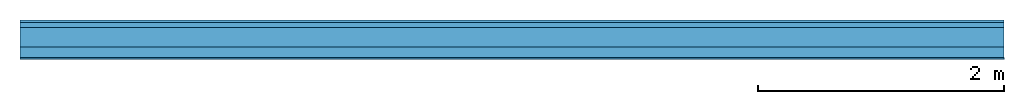
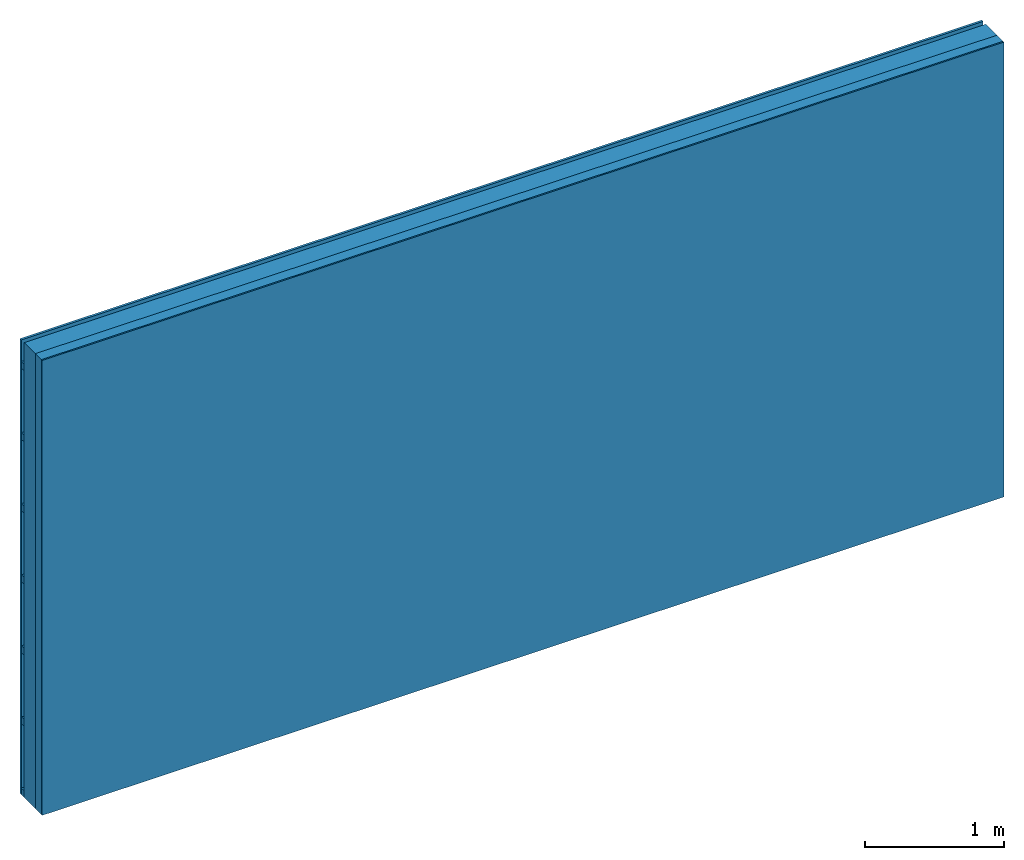
# One storey: 3 plates, 2 members, 1 element without a shape of its own.
"""IFC4 building model written with IfcOpenShell, lengths in metres."""

from ifc_helpers import new_model, si_unit, derived_unit, direction, frame, frame_2d, origin, origin_with_axes, place, context, project, spatial, rectangle, extrude, material, layer, layer_set, type_object, element, aggregate, save


model = new_model("IFC4")

# Units and contexts
plan_context = context("Plan", 3, precision=1e-05, world=origin(), true_north=direction((0.0, 1.0)))
model_context = context("Model", 3, precision=1e-05, world=origin(), true_north=direction((0.0, 1.0)))
ifc_project = project(units=[si_unit("LENGTHUNIT", "METRE"), derived_unit("SOUNDPRESSUREUNIT", [(si_unit("PRESSUREUNIT", "PASCAL", prefix="MICRO"), 0)]), si_unit("ENERGYUNIT", "JOULE", prefix="MEGA"), si_unit("MASSUNIT", "GRAM", prefix="KILO"), derived_unit("THERMALTRANSMITTANCEUNIT", [(si_unit("POWERUNIT", "WATT"), 1), (si_unit("AREAUNIT", "SQUARE_METRE"), -1), (si_unit("THERMODYNAMICTEMPERATUREUNIT", "KELVIN"), -1)]), derived_unit("AREADENSITYUNIT", [(si_unit("MASSUNIT", "GRAM", prefix="KILO"), 1), (si_unit("AREAUNIT", "SQUARE_METRE"), -1)]), derived_unit("USERDEFINED", [(si_unit("ENERGYUNIT", "JOULE", prefix="MEGA"), 1), (si_unit("AREAUNIT", "SQUARE_METRE"), -1)])], contexts=[plan_context, model_context])

# Site, building, storey
site = spatial("IfcSite", under=ifc_project)
building_placement = place(None, origin())
building = spatial("IfcBuilding", under=site, at=building_placement)
storey_placement = place(building_placement, origin())
storey = spatial("IfcBuildingStorey", under=building, at=storey_placement)

# Wall, members, plates
ifc_material_1 = material(Name="Wood cladding horizontal, closed")
ifc_layer_1 = layer(ifc_material_1, 0.02, Name="Cover 1st layer")
ifc_layer_2 = layer(None, 0.04, Name="Battens / profiles (ventilation)")
ifc_material_2 = material(Category="10.009")
ifc_layer_3 = layer(ifc_material_2, 0.16, Name="outside 1st layer")
ifc_material_3 = material(Name="of the art")
ifc_layer_4 = layer(ifc_material_3, 0.0, Name="Bond")
ifc_layer_5 = layer(None, 0.087, Name="Support")
ifc_layer_6 = layer(ifc_material_3, 0.0, Name="Bond")
ifc_material_4 = material(Name="Plasterboard type A", Category="03.008")
ifc_layer_7 = layer(ifc_material_4, 0.0125, Name="1st layer")
ifc_material_5 = material(Name="joints", Category="04.017")
ifc_layer_8 = layer(ifc_material_5, 0.0, Name="Surface")
ifc_layer_set = layer_set([ifc_layer_1, ifc_layer_2, ifc_layer_3, ifc_layer_4, ifc_layer_5, ifc_layer_6, ifc_layer_7, ifc_layer_8])
wall_type = type_object("IfcWallType", Name="D1009", PredefinedType="NOTDEFINED", material=ifc_layer_set)
wall_placement = place(None, frame((0.0, 0.0, 0.0), z_axis=(0.0, -1.0, 0.0), x_axis=(1.0, 0.0, 0.0)))
wall = element("IfcWall", 1, at=wall_placement, inside=storey, type_object=wall_type, material=ifc_layer_set, Name="Wall #1")
ifc_material_6 = material()
member_1_placement = place(wall_placement, origin())
member_1 = element("IfcMember", 2, at=member_1_placement, material=ifc_material_6, Name="Battens / profiles (ventilation)", context=plan_context, shape_type="SweptSolid", body=[
    extrude(rectangle(XDim=0.06, YDim=0.04, at=frame_2d((0.03, 0.02), x_axis=(1.0, 0.0))), frame((0.0, 0.0, 0.02), z_axis=(1.0, 0.0, 0.0), x_axis=(0.0, 1.0, 0.0)), (0.0, 0.0, 1.0), 8.0),
    extrude(rectangle(XDim=0.06, YDim=0.04, at=frame_2d((0.03, 0.02), x_axis=(1.0, 0.0))), frame((0.0, 0.625, 0.02), z_axis=(1.0, 0.0, 0.0), x_axis=(0.0, 1.0, 0.0)), (0.0, 0.0, 1.0), 8.0),
    extrude(rectangle(XDim=0.06, YDim=0.04, at=frame_2d((0.03, 0.02), x_axis=(1.0, 0.0))), frame((0.0, 1.25, 0.02), z_axis=(1.0, 0.0, 0.0), x_axis=(0.0, 1.0, 0.0)), (0.0, 0.0, 1.0), 8.0),
    extrude(rectangle(XDim=0.06, YDim=0.04, at=frame_2d((0.03, 0.02), x_axis=(1.0, 0.0))), frame((0.0, 1.875, 0.02), z_axis=(1.0, 0.0, 0.0), x_axis=(0.0, 1.0, 0.0)), (0.0, 0.0, 1.0), 8.0),
    extrude(rectangle(XDim=0.06, YDim=0.04, at=frame_2d((0.03, 0.02), x_axis=(1.0, 0.0))), frame((0.0, 2.5, 0.02), z_axis=(1.0, 0.0, 0.0), x_axis=(0.0, 1.0, 0.0)), (0.0, 0.0, 1.0), 8.0),
    extrude(rectangle(XDim=0.06, YDim=0.04, at=frame_2d((0.03, 0.02), x_axis=(1.0, 0.0))), frame((0.0, 3.125, 0.02), z_axis=(1.0, 0.0, 0.0), x_axis=(0.0, 1.0, 0.0)), (0.0, 0.0, 1.0), 8.0),
    extrude(rectangle(XDim=0.06, YDim=0.04, at=frame_2d((0.03, 0.02), x_axis=(1.0, 0.0))), frame((0.0, 3.75, 0.02), z_axis=(1.0, 0.0, 0.0), x_axis=(0.0, 1.0, 0.0)), (0.0, 0.0, 1.0), 8.0),
])
ifc_material_7 = material(Name="Solid timber panel")
member_2_placement = place(wall_placement, origin())
member_2 = element("IfcMember", 3, at=member_2_placement, material=ifc_material_7, Name="Support", context=plan_context, shape_type="SweptSolid", body=[
    extrude(rectangle(XDim=1.0, YDim=0.087, at=frame_2d((0.5, 0.0435), x_axis=(1.0, 0.0))), frame((0.0, 4.0, 0.22), z_axis=(0.0, -1.0, 0.0), x_axis=(1.0, 0.0, 0.0)), (0.0, 0.0, 1.0), 4.0),
    extrude(rectangle(XDim=1.0, YDim=0.087, at=frame_2d((0.5, 0.0435), x_axis=(1.0, 0.0))), frame((1.0, 4.0, 0.22), z_axis=(0.0, -1.0, 0.0), x_axis=(1.0, 0.0, 0.0)), (0.0, 0.0, 1.0), 4.0),
    extrude(rectangle(XDim=1.0, YDim=0.087, at=frame_2d((0.5, 0.0435), x_axis=(1.0, 0.0))), frame((2.0, 4.0, 0.22), z_axis=(0.0, -1.0, 0.0), x_axis=(1.0, 0.0, 0.0)), (0.0, 0.0, 1.0), 4.0),
    extrude(rectangle(XDim=1.0, YDim=0.087, at=frame_2d((0.5, 0.0435), x_axis=(1.0, 0.0))), frame((3.0, 4.0, 0.22), z_axis=(0.0, -1.0, 0.0), x_axis=(1.0, 0.0, 0.0)), (0.0, 0.0, 1.0), 4.0),
    extrude(rectangle(XDim=1.0, YDim=0.087, at=frame_2d((0.5, 0.0435), x_axis=(1.0, 0.0))), frame((4.0, 4.0, 0.22), z_axis=(0.0, -1.0, 0.0), x_axis=(1.0, 0.0, 0.0)), (0.0, 0.0, 1.0), 4.0),
    extrude(rectangle(XDim=1.0, YDim=0.087, at=frame_2d((0.5, 0.0435), x_axis=(1.0, 0.0))), frame((5.0, 4.0, 0.22), z_axis=(0.0, -1.0, 0.0), x_axis=(1.0, 0.0, 0.0)), (0.0, 0.0, 1.0), 4.0),
    extrude(rectangle(XDim=1.0, YDim=0.087, at=frame_2d((0.5, 0.0435), x_axis=(1.0, 0.0))), frame((6.0, 4.0, 0.22), z_axis=(0.0, -1.0, 0.0), x_axis=(1.0, 0.0, 0.0)), (0.0, 0.0, 1.0), 4.0),
    extrude(rectangle(XDim=1.0, YDim=0.087, at=frame_2d((0.5, 0.0435), x_axis=(1.0, 0.0))), frame((7.0, 4.0, 0.22), z_axis=(0.0, -1.0, 0.0), x_axis=(1.0, 0.0, 0.0)), (0.0, 0.0, 1.0), 4.0),
])
plate_1_placement = place(wall_placement, origin())
plate_1 = element("IfcPlate", 4, at=plate_1_placement, material=ifc_material_1, Name="Cover 1st layer", context=plan_context, shape_type="SweptSolid", body=[
    extrude(rectangle(XDim=8.0, YDim=4.0, at=frame_2d((4.0, 2.0), x_axis=(1.0, 0.0))), origin_with_axes(), (0.0, 0.0, 1.0), 0.02),
])
plate_2_placement = place(wall_placement, origin())
plate_2 = element("IfcPlate", 5, at=plate_2_placement, material=ifc_material_2, Name="outside 1st layer", context=plan_context, shape_type="SweptSolid", body=[
    extrude(rectangle(XDim=8.0, YDim=4.0, at=frame_2d((4.0, 2.0), x_axis=(1.0, 0.0))), frame((0.0, 0.0, 0.06), z_axis=(0.0, 0.0, 1.0), x_axis=(1.0, 0.0, 0.0)), (0.0, 0.0, 1.0), 0.16),
])
plate_3_placement = place(wall_placement, origin())
plate_3 = element("IfcPlate", 6, at=plate_3_placement, material=ifc_material_4, Name="1st layer", context=plan_context, shape_type="SweptSolid", body=[
    extrude(rectangle(XDim=8.0, YDim=4.0, at=frame_2d((4.0, 2.0), x_axis=(1.0, 0.0))), frame((0.0, 0.0, 0.307), z_axis=(0.0, 0.0, 1.0), x_axis=(1.0, 0.0, 0.0)), (0.0, 0.0, 1.0), 0.0125),
])
aggregate(wall, [plate_1, member_1, plate_2, member_2, plate_3])

save(model, "model.ifc")
